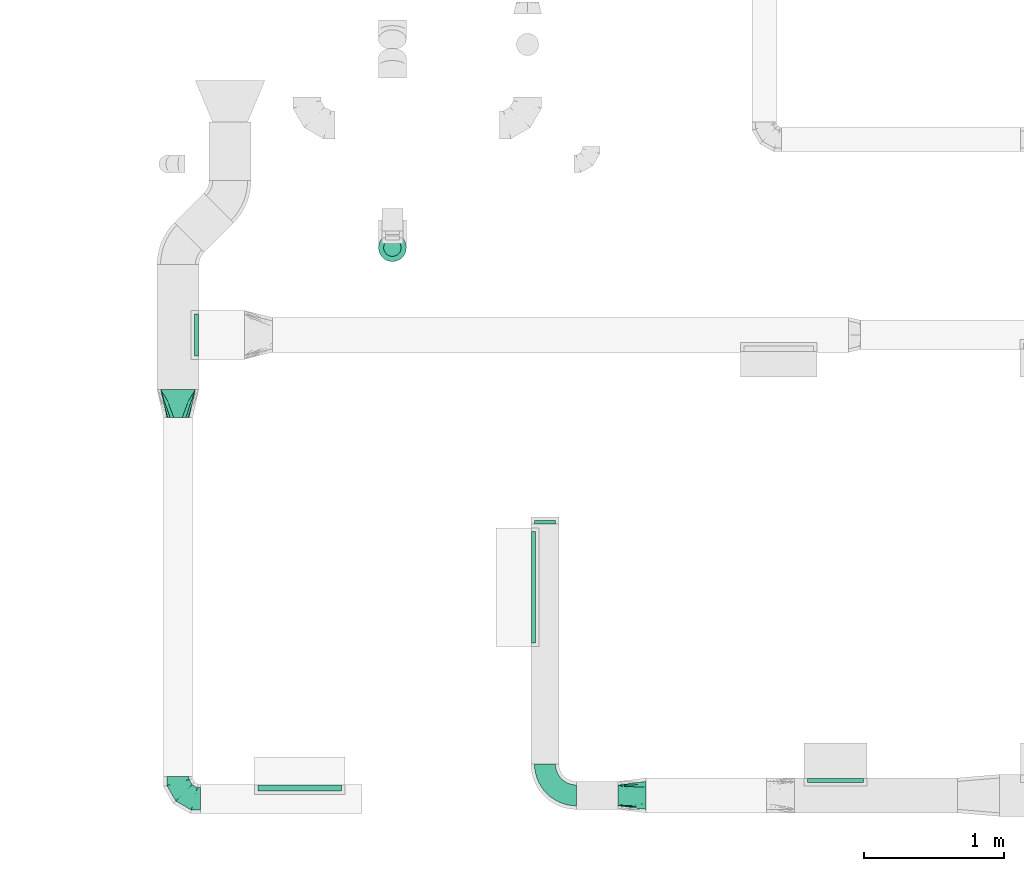
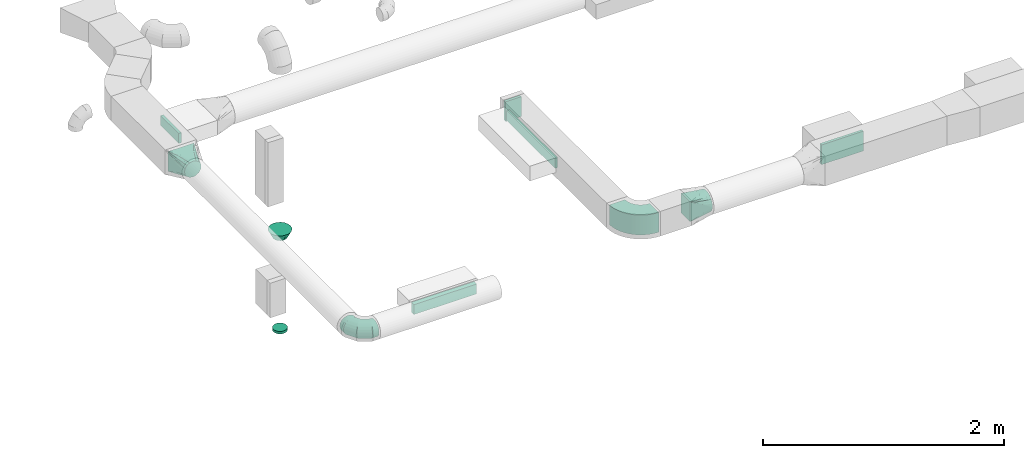
# One storey, part 49 of 97: 11 flow fittings.
"""IFC2X3 building model written with IfcOpenShell, lengths in millimetres."""

from ifc_helpers import new_model, entity, si_unit, converted_unit, derived_unit, direction, frame, frame_2d, origin, origin_2d_with_axis, place, context, subcontext, project, spatial, polyline, circle_curve, parameter, trimmed, segment, composite_curve, rectangle, circle, outline, extrude, faceted_brep, source, transform, mapped, material, type_object, type_shapes, element, save


model = new_model("IFC2X3")

# Units and contexts
model_context = context("Model", 3, precision=0.01, world=origin(), true_north=direction((6.12303176911189e-17, 1.0)))
body_context = subcontext(model_context, "Body", "Model", "MODEL_VIEW")
ifc_project = project(units=[si_unit("LENGTHUNIT", "METRE", prefix="MILLI"), si_unit("AREAUNIT", "SQUARE_METRE"), si_unit("VOLUMEUNIT", "CUBIC_METRE"), converted_unit("PLANEANGLEUNIT", "DEGREE", entity("IfcRatioMeasure", 0.0174532925199433), si_unit("PLANEANGLEUNIT", "RADIAN"), dimensions=[0, 0, 0, 0, 0, 0, 0]), si_unit("MASSUNIT", "GRAM", prefix="KILO"), derived_unit("MASSDENSITYUNIT", [(si_unit("MASSUNIT", "GRAM", prefix="KILO"), 1), (si_unit("LENGTHUNIT", "METRE"), -3)]), derived_unit("MOMENTOFINERTIAUNIT", [(si_unit("LENGTHUNIT", "METRE"), 4)]), si_unit("TIMEUNIT", "SECOND"), si_unit("FREQUENCYUNIT", "HERTZ"), si_unit("THERMODYNAMICTEMPERATUREUNIT", "DEGREE_CELSIUS"), derived_unit("THERMALTRANSMITTANCEUNIT", [(si_unit("MASSUNIT", "GRAM", prefix="KILO"), 1), (si_unit("THERMODYNAMICTEMPERATUREUNIT", "KELVIN"), -1), (si_unit("TIMEUNIT", "SECOND"), -3)]), derived_unit("VOLUMETRICFLOWRATEUNIT", [(si_unit("LENGTHUNIT", "METRE"), 3), (si_unit("TIMEUNIT", "SECOND"), -1)]), derived_unit("MASSFLOWRATEUNIT", [(si_unit("MASSUNIT", "GRAM", prefix="KILO"), 1), (si_unit("TIMEUNIT", "SECOND"), -1)]), derived_unit("ROTATIONALFREQUENCYUNIT", [(si_unit("TIMEUNIT", "SECOND"), -1)]), si_unit("ELECTRICCURRENTUNIT", "AMPERE"), si_unit("ELECTRICVOLTAGEUNIT", "VOLT"), si_unit("POWERUNIT", "WATT"), si_unit("FORCEUNIT", "NEWTON", prefix="KILO"), si_unit("ILLUMINANCEUNIT", "LUX"), si_unit("LUMINOUSFLUXUNIT", "LUMEN"), si_unit("LUMINOUSINTENSITYUNIT", "CANDELA"), derived_unit("USERDEFINED", [(si_unit("MASSUNIT", "GRAM", prefix="KILO"), -1), (si_unit("LENGTHUNIT", "METRE"), -2), (si_unit("TIMEUNIT", "SECOND"), 3), (si_unit("LUMINOUSFLUXUNIT", "LUMEN"), 1)]), derived_unit("LINEARVELOCITYUNIT", [(si_unit("LENGTHUNIT", "METRE"), 1), (si_unit("TIMEUNIT", "SECOND"), -1)]), si_unit("PRESSUREUNIT", "PASCAL"), derived_unit("USERDEFINED", [(si_unit("LENGTHUNIT", "METRE"), -2), (si_unit("MASSUNIT", "GRAM", prefix="KILO"), 1), (si_unit("TIMEUNIT", "SECOND"), -2)]), derived_unit("LINEARFORCEUNIT", [(si_unit("MASSUNIT", "GRAM", prefix="KILO"), 1), (si_unit("LENGTHUNIT", "METRE"), 1), (si_unit("TIMEUNIT", "SECOND"), -2), (si_unit("LENGTHUNIT", "METRE"), -1)]), derived_unit("PLANARFORCEUNIT", [(si_unit("MASSUNIT", "GRAM", prefix="KILO"), 1), (si_unit("LENGTHUNIT", "METRE"), 1), (si_unit("TIMEUNIT", "SECOND"), -2), (si_unit("LENGTHUNIT", "METRE"), -2)])], contexts=[model_context])

# Site, building, storey
site_placement = place(None, origin())
site = spatial("IfcSite", under=ifc_project, at=site_placement, CompositionType="ELEMENT")
building_placement = place(site_placement, origin())
building = spatial("IfcBuilding", under=site, at=building_placement, CompositionType="ELEMENT")
storey_placement = place(building_placement, frame((0.0, 0.0, -4900.0)))
storey = spatial("IfcBuildingStorey", under=building, at=storey_placement, CompositionType="ELEMENT", Elevation=-4900.0)

# Flow fittings
ifc_material = material()
duct_fitting_type_1 = type_object("IfcDuctFittingType", PredefinedType="NOTDEFINED", material=ifc_material)
shared_shape_1 = source(origin(), body_context, "Body", "SweptSolid", [
    extrude(rectangle(XDim=26.0960000000006, YDim=400.0, at=origin_2d_with_axis()), frame((6.95, 0.0, -100.0)), (0.0, 0.0, 1.0), 200.0),
])
type_shapes(duct_fitting_type_1, [shared_shape_1])
flow_fitting_1_placement = place(storey_placement, frame((46800.54, 373.87, 4200.0), z_axis=(0.0, 0.0, -1.0), x_axis=(0.0, 1.0, 0.0)))
element("IfcFlowFitting", 1, at=flow_fitting_1_placement, inside=storey, type_object=duct_fitting_type_1, material=ifc_material, context=body_context, shape_type="MappedRepresentation", body=[
    mapped(shared_shape_1, transform((0.0, 0.0, 0.0), scale=1.0)),
])
duct_fitting_type_2 = type_object("IfcDuctFittingType", PredefinedType="NOTDEFINED", material=ifc_material)
shared_shape_2 = source(origin(), body_context, "Body", "SweptSolid", [
    extrude(rectangle(XDim=600.0, YDim=43.6460200160145, at=origin_2d_with_axis()), frame((-1.82, 0.0, -50.0), z_axis=(0.0, 0.0, 1.0), x_axis=(0.0, -1.0, 0.0)), (0.0, 0.0, 1.0), 100.0),
])
type_shapes(duct_fitting_type_2, [shared_shape_2])
flow_fitting_2_placement = place(storey_placement, frame((42962.03, 328.86, 4050.0), z_axis=(0.0, 0.0, -1.0), x_axis=(0.0, 1.0, 0.0)))
element("IfcFlowFitting", 2, at=flow_fitting_2_placement, inside=storey, type_object=duct_fitting_type_2, material=ifc_material, context=body_context, shape_type="MappedRepresentation", body=[
    mapped(shared_shape_2, transform((0.0, 0.0, 0.0), scale=1.0)),
])
duct_fitting_type_3 = type_object("IfcDuctFittingType", PredefinedType="NOTDEFINED", material=ifc_material)
shared_shape_3 = source(origin(), body_context, "Body", "SweptSolid", [
    extrude(rectangle(XDim=300.0, YDim=26.0960000000173, at=origin_2d_with_axis()), frame((6.95, 0.0, -50.0), z_axis=(0.0, 0.0, 1.0), x_axis=(0.0, -1.0, 0.0)), (0.0, 0.0, 1.0), 100.0),
])
type_shapes(duct_fitting_type_3, [shared_shape_3])
flow_fitting_3_placement = place(storey_placement, frame((42214.6, 3573.53, 4050.0), z_axis=(0.0, 0.0, -1.0), x_axis=(1.0, 0.0, 0.0)))
element("IfcFlowFitting", 3, at=flow_fitting_3_placement, inside=storey, type_object=duct_fitting_type_3, material=ifc_material, context=body_context, shape_type="MappedRepresentation", body=[
    mapped(shared_shape_3, transform((0.0, 0.0, 0.0), scale=1.0)),
])
duct_fitting_type_4 = type_object("IfcDuctFittingType", PredefinedType="NOTDEFINED", material=ifc_material)
shared_shape_4 = source(origin(), body_context, "Body", "SweptSolid", [
    extrude(rectangle(XDim=24.9999999999999, YDim=150.0, at=origin_2d_with_axis()), frame((12.5, 0.0, -100.0)), (0.0, 0.0, 1.0), 200.0),
])
type_shapes(duct_fitting_type_4, [shared_shape_4])
flow_fitting_4_placement = place(storey_placement, frame((44718.59, 2217.15, 4200.0), z_axis=(0.0, 0.0, 1.0), x_axis=(0.0, 1.0, 0.0)))
element("IfcFlowFitting", 4, at=flow_fitting_4_placement, inside=storey, type_object=duct_fitting_type_4, material=ifc_material, context=body_context, shape_type="MappedRepresentation", body=[
    mapped(shared_shape_4, transform((0.0, 0.0, 0.0), scale=1.0)),
])
duct_fitting_type_5 = type_object("IfcDuctFittingType", PredefinedType="NOTDEFINED", material=ifc_material)
shared_shape_5 = source(origin(), body_context, "Body", "SweptSolid", [
    extrude(rectangle(XDim=26.0960000000012, YDim=800.0, at=origin_2d_with_axis()), frame((6.95, 0.0, -50.0)), (0.0, 0.0, 1.0), 100.0),
])
type_shapes(duct_fitting_type_5, [shared_shape_5])
flow_fitting_5_placement = place(storey_placement, frame((44643.59, 1766.12, 4200.0), z_axis=(0.0, 0.0, -1.0), x_axis=(-1.0, 0.0, 0.0)))
element("IfcFlowFitting", 5, at=flow_fitting_5_placement, inside=storey, type_object=duct_fitting_type_5, material=ifc_material, context=body_context, shape_type="MappedRepresentation", body=[
    mapped(shared_shape_5, transform((0.0, 0.0, 0.0), scale=1.0)),
])
duct_fitting_type_6 = type_object("IfcDuctFittingType", PredefinedType="NOTDEFINED", material=ifc_material)
shared_shape_6 = source(origin(), body_context, "Body", "SweptSolid", [
    extrude(circle(Radius=62.4999999999996, at=origin_2d_with_axis()), frame((0.0, 0.0, 0.0), z_axis=(1.0, 0.0, 0.0), x_axis=(0.0, 1.0, 0.0)), (0.0, 0.0, 1.0), 25.0000000000018),
])
type_shapes(duct_fitting_type_6, [shared_shape_6])
flow_fitting_6_placement = place(storey_placement, frame((43625.66, 4198.32, 1174.5), z_axis=(-1.0, 0.0, 0.0), x_axis=(0.0, 0.0, -1.0)))
element("IfcFlowFitting", 6, at=flow_fitting_6_placement, inside=storey, type_object=duct_fitting_type_6, material=ifc_material, context=body_context, shape_type="MappedRepresentation", body=[
    mapped(shared_shape_6, transform((0.0, 0.0, 0.0), scale=1.0)),
])
duct_fitting_type_7 = type_object("IfcDuctFittingType", PredefinedType="NOTDEFINED", material=ifc_material)
shared_shape_7 = source(origin(), body_context, "Body", "Brep", [
    faceted_brep([(-160.0, 0.0, -80.0), (-160.0, -20.71, -77.27), (-160.0, -40.0, -69.28), (-160.0, -56.57, -56.57), (-160.0, -69.28, -40.0), (-160.0, -77.27, -20.71), (-160.0, -80.0, 0.0), (-160.0, -77.27, 20.71), (-160.0, -69.28, 40.0), (-160.0, -56.57, 56.57), (-160.0, -40.0, 69.28), (-160.0, -20.71, 77.27), (-160.0, 0.0, 80.0), (-160.0, 20.71, 77.27), (-160.0, 40.0, 69.28), (-160.0, 56.57, 56.57), (-160.0, 69.28, 40.0), (-160.0, 77.27, 20.71), (-160.0, 80.0, 0.0), (-160.0, 77.27, -20.71), (-160.0, 69.28, -40.0), (-160.0, 56.57, -56.57), (-160.0, 40.0, -69.28), (-160.0, 20.71, -77.27), (-122.68, 20.71, 77.27), (-127.85, 40.0, 69.28), (-117.13, 0.0, 80.0), (-132.29, 56.57, 56.57), (-137.83, 77.27, 20.71), (-138.56, 80.0, 0.0), (-135.69, 69.28, 40.0), (-135.69, 69.28, -40.0), (-132.29, 56.57, -56.57), (-137.83, 77.27, -20.71), (-122.68, 20.71, -77.27), (-117.13, 0.0, -80.0), (-127.85, 40.0, -69.28), (-111.58, -20.71, -77.27), (-106.41, -40.0, -69.28), (-101.97, -56.57, -56.57), (-98.56, -69.28, -40.0), (-96.42, -77.27, -20.71), (-95.69, -80.0, 0.0), (-96.42, -77.27, 20.71), (-98.56, -69.28, 40.0), (-101.97, -56.57, 56.57), (-106.41, -40.0, 69.28), (-111.58, -20.71, 77.27), (-58.03, 58.03, 77.27), (-72.15, 72.15, 69.28), (-42.87, 42.87, 80.0), (-84.28, 84.28, 56.57), (-93.59, 93.59, 40.0), (-99.44, 99.44, 20.71), (-101.44, 101.44, 0.0), (-99.44, 99.44, -20.71), (-93.59, 93.59, -40.0), (-84.28, 84.28, -56.57), (-58.03, 58.03, -77.27), (-42.87, 42.87, -80.0), (-72.15, 72.15, -69.28), (-27.71, 27.71, -77.27), (-13.59, 13.59, -69.28), (-1.46, 1.46, -56.57), (7.85, -7.85, -40.0), (13.7, -13.7, -20.71), (15.69, -15.69, 0.0), (13.7, -13.7, 20.71), (7.85, -7.85, 40.0), (-1.46, 1.46, 56.57), (-13.59, 13.59, 69.28), (-27.71, 27.71, 77.27), (-20.71, 122.68, 77.27), (-40.0, 127.85, 69.28), (0.0, 117.13, 80.0), (-56.57, 132.29, 56.57), (-69.28, 135.69, 40.0), (-77.27, 137.83, 20.71), (-80.0, 138.56, 0.0), (-77.27, 137.83, -20.71), (-69.28, 135.69, -40.0), (-56.57, 132.29, -56.57), (-20.71, 122.68, -77.27), (0.0, 117.13, -80.0), (-40.0, 127.85, -69.28), (20.71, 111.58, -77.27), (40.0, 106.41, -69.28), (56.57, 101.97, -56.57), (69.28, 98.56, -40.0), (77.27, 96.42, -20.71), (80.0, 95.69, 0.0), (77.27, 96.42, 20.71), (69.28, 98.56, 40.0), (56.57, 101.97, 56.57), (40.0, 106.41, 69.28), (20.71, 111.58, 77.27), (-20.71, 160.0, -77.27), (-40.0, 160.0, -69.28), (-56.57, 160.0, -56.57), (-69.28, 160.0, -40.0), (-77.27, 160.0, -20.71), (-80.0, 160.0, 0.0), (-77.27, 160.0, 20.71), (-69.28, 160.0, 40.0), (-56.57, 160.0, 56.57), (-40.0, 160.0, 69.28), (-20.71, 160.0, 77.27), (0.0, 160.0, 80.0), (20.71, 160.0, 77.27), (40.0, 160.0, 69.28), (56.57, 160.0, 56.57), (69.28, 160.0, 40.0), (77.27, 160.0, 20.71), (80.0, 160.0, 0.0), (77.27, 160.0, -20.71), (69.28, 160.0, -40.0), (56.57, 160.0, -56.57), (40.0, 160.0, -69.28), (20.71, 160.0, -77.27), (0.0, 160.0, -80.0)], [[[0, 1, 2, 3, 4, 5, 6, 7, 8, 9, 10, 11, 12, 13, 14, 15, 16, 17, 18, 19, 20, 21, 22, 23]], [[24, 25, 14, 13]], [[26, 24, 13, 12]], [[14, 25, 27, 15]], [[28, 29, 18, 17]], [[30, 28, 17, 16]], [[15, 27, 30, 16]], [[20, 31, 32, 21]], [[33, 31, 20, 19]], [[18, 29, 33, 19]], [[34, 35, 0, 23]], [[36, 34, 23, 22]], [[32, 36, 22, 21]], [[1, 0, 35, 37]], [[2, 1, 37, 38]], [[3, 2, 38, 39]], [[5, 4, 40, 41]], [[6, 5, 41, 42]], [[39, 40, 4, 3]], [[6, 42, 43, 7]], [[7, 43, 44, 8]], [[8, 44, 45, 9]], [[9, 45, 46, 10]], [[10, 46, 47, 11]], [[26, 12, 11, 47]], [[48, 49, 25, 24]], [[50, 48, 24, 26]], [[27, 25, 49, 51]], [[52, 53, 28, 30]], [[51, 52, 30, 27]], [[29, 28, 53, 54]], [[55, 56, 31, 33]], [[54, 55, 33, 29]], [[32, 31, 56, 57]], [[58, 59, 35, 34]], [[60, 58, 34, 36]], [[57, 60, 36, 32]], [[37, 35, 59, 61]], [[38, 37, 61, 62]], [[39, 38, 62, 63]], [[41, 40, 64, 65]], [[42, 41, 65, 66]], [[63, 64, 40, 39]], [[43, 42, 66, 67]], [[44, 43, 67, 68]], [[68, 69, 45, 44]], [[46, 45, 69, 70]], [[47, 46, 70, 71]], [[26, 47, 71, 50]], [[72, 73, 49, 48]], [[74, 72, 48, 50]], [[51, 49, 73, 75]], [[76, 77, 53, 52]], [[75, 76, 52, 51]], [[54, 53, 77, 78]], [[79, 80, 56, 55]], [[78, 79, 55, 54]], [[57, 56, 80, 81]], [[82, 83, 59, 58]], [[84, 82, 58, 60]], [[81, 84, 60, 57]], [[61, 59, 83, 85]], [[62, 61, 85, 86]], [[63, 62, 86, 87]], [[65, 64, 88, 89]], [[66, 65, 89, 90]], [[87, 88, 64, 63]], [[67, 66, 90, 91]], [[68, 67, 91, 92]], [[92, 93, 69, 68]], [[70, 69, 93, 94]], [[71, 70, 94, 95]], [[50, 71, 95, 74]], [[96, 97, 98, 99, 100, 101, 102, 103, 104, 105, 106, 107, 108, 109, 110, 111, 112, 113, 114, 115, 116, 117, 118, 119]], [[72, 74, 107, 106]], [[73, 72, 106, 105]], [[75, 73, 105, 104]], [[77, 76, 103, 102]], [[78, 77, 102, 101]], [[75, 104, 103, 76]], [[78, 101, 100, 79]], [[79, 100, 99, 80]], [[80, 99, 98, 81]], [[84, 97, 96, 82]], [[82, 96, 119, 83]], [[84, 81, 98, 97]], [[118, 117, 86, 85]], [[119, 118, 85, 83]], [[116, 87, 86, 117]], [[88, 115, 114, 89]], [[89, 114, 113, 90]], [[115, 88, 87, 116]], [[112, 111, 92, 91]], [[113, 112, 91, 90]], [[111, 110, 93, 92]], [[95, 94, 109, 108]], [[74, 95, 108, 107]], [[110, 109, 94, 93]]]),
])
type_shapes(duct_fitting_type_7, [shared_shape_7])
flow_fitting_7_placement = place(storey_placement, frame((42089.6, 248.86, 4050.0), z_axis=(0.0, 0.0, 1.0), x_axis=(0.0, -1.0, 0.0)))
element("IfcFlowFitting", 7, at=flow_fitting_7_placement, inside=storey, type_object=duct_fitting_type_7, material=ifc_material, context=body_context, shape_type="MappedRepresentation", body=[
    mapped(shared_shape_7, transform((0.0, 0.0, 0.0), scale=1.0)),
])
duct_fitting_type_8 = type_object("IfcDuctFittingType", PredefinedType="NOTDEFINED", material=ifc_material)
shared_shape_8 = source(origin(), body_context, "Body", "Brep", [
    faceted_brep([(200.0, 30.61, 73.91), (200.0, 22.87, 75.45), (200.0, 15.12, 76.99), (200.0, 11.34, 77.74), (200.0, 7.56, 78.5), (200.0, 0.0, 80.0), (200.0, -7.56, 78.5), (200.0, -15.12, 76.99), (200.0, -18.99, 76.22), (200.0, -22.87, 75.45), (200.0, -30.61, 73.91), (200.0, -37.1, 69.57), (200.0, -43.59, 65.24), (200.0, -50.08, 60.9), (200.0, -56.57, 56.57), (200.0, -60.9, 50.08), (200.0, -65.24, 43.59), (200.0, -69.57, 37.1), (200.0, -73.91, 30.61), (200.0, -75.45, 22.87), (200.0, -76.99, 15.12), (200.0, -77.74, 11.34), (200.0, -78.5, 7.56), (200.0, -80.0, 0.0), (200.0, -78.5, -7.56), (200.0, -76.99, -15.12), (200.0, -76.22, -18.99), (200.0, -75.45, -22.87), (200.0, -73.91, -30.61), (200.0, -69.57, -37.1), (200.0, -65.24, -43.59), (200.0, -60.9, -50.08), (200.0, -56.57, -56.57), (200.0, -50.08, -60.9), (200.0, -43.59, -65.24), (200.0, -37.1, -69.57), (200.0, -30.61, -73.91), (200.0, -22.87, -75.45), (200.0, -15.12, -76.99), (200.0, -11.34, -77.74), (200.0, -7.56, -78.5), (200.0, 0.0, -80.0), (200.0, 7.56, -78.5), (200.0, 15.12, -76.99), (200.0, 18.99, -76.22), (200.0, 22.87, -75.45), (200.0, 30.61, -73.91), (200.0, 37.1, -69.57), (200.0, 43.59, -65.24), (200.0, 50.08, -60.9), (200.0, 56.57, -56.57), (200.0, 60.9, -50.08), (200.0, 65.24, -43.59), (200.0, 69.57, -37.1), (200.0, 73.91, -30.61), (200.0, 75.45, -22.87), (200.0, 76.99, -15.12), (200.0, 77.74, -11.34), (200.0, 78.5, -7.56), (200.0, 80.0, 0.0), (200.0, 78.5, 7.56), (200.0, 76.99, 15.12), (200.0, 76.22, 18.99), (200.0, 75.45, 22.87), (200.0, 73.91, 30.61), (200.0, 69.57, 37.1), (200.0, 65.24, 43.59), (200.0, 60.9, 50.08), (200.0, 56.57, 56.57), (200.0, 50.08, 60.9), (200.0, 43.59, 65.24), (200.0, 37.1, 69.57), (0.0, -125.0, 100.0), (0.0, 125.0, 100.0), (0.0, 125.0, -100.0), (0.0, -125.0, -100.0), (52.06, -92.46, 94.79), (78.09, -76.2, 92.19), (176.03, -14.98, 82.4), (152.06, -29.96, 84.79), (128.09, -44.95, 87.19), (104.11, -59.93, 89.59), (100.0, -92.44, 76.52), (78.09, -107.43, 60.96), (104.11, -101.57, 47.94), (128.09, -96.18, 35.96), (152.06, -90.79, 23.97), (164.04, -88.09, 17.98), (176.03, -85.39, 11.99), (26.03, -119.14, 86.99), (52.06, -113.29, 73.97), (26.03, -108.73, 97.4), (26.03, -119.14, -86.99), (52.06, -113.29, -73.97), (78.09, -107.43, -60.96), (104.11, -101.57, -47.94), (128.09, -96.18, -35.96), (152.06, -90.79, -23.97), (176.03, -85.39, -11.99), (100.0, -89.02, -79.94), (78.09, -76.2, -92.19), (104.11, -59.93, -89.59), (128.09, -44.95, -87.19), (152.06, -29.96, -84.79), (164.04, -22.47, -83.6), (176.03, -14.98, -82.4), (26.03, -108.73, -97.4), (52.06, -92.46, -94.79), (26.03, 108.73, -97.4), (52.06, 92.46, -94.79), (78.09, 76.2, -92.19), (104.11, 59.93, -89.59), (128.09, 44.95, -87.19), (152.06, 29.96, -84.79), (176.03, 14.98, -82.4), (100.0, 92.44, -76.52), (78.09, 107.43, -60.96), (104.11, 101.57, -47.94), (128.09, 96.18, -35.96), (152.06, 90.79, -23.97), (164.04, 88.09, -17.98), (176.03, 85.39, -11.99), (26.03, 119.14, -86.99), (52.06, 113.29, -73.97), (26.03, 119.14, 86.99), (52.06, 113.29, 73.97), (78.09, 107.43, 60.96), (104.11, 101.57, 47.94), (128.09, 96.18, 35.96), (152.06, 90.79, 23.97), (176.03, 85.39, 11.99), (100.0, 89.02, 79.94), (78.09, 76.2, 92.19), (104.11, 59.93, 89.59), (128.09, 44.95, 87.19), (152.06, 29.96, 84.79), (164.04, 22.47, 83.6), (176.03, 14.98, 82.4), (26.03, 108.73, 97.4), (52.06, 92.46, 94.79)], [[[0, 1, 2, 3, 4, 5, 6, 7, 8, 9, 10, 11, 12, 13, 14, 15, 16, 17, 18, 19, 20, 21, 22, 23, 24, 25, 26, 27, 28, 29, 30, 31, 32, 33, 34, 35, 36, 37, 38, 39, 40, 41, 42, 43, 44, 45, 46, 47, 48, 49, 50, 51, 52, 53, 54, 55, 56, 57, 58, 59, 60, 61, 62, 63, 64, 65, 66, 67, 68, 69, 70, 71]], [[72, 73, 74, 75]], [[76, 12, 77]], [[12, 11, 10, 77]], [[78, 79, 80, 81, 77, 10, 9, 8, 7, 6, 5]], [[13, 82, 14]], [[20, 19, 18, 83, 84, 85, 86, 87, 88, 23, 22, 21]], [[82, 72, 89]], [[82, 15, 14]], [[83, 16, 90]], [[91, 72, 82]], [[18, 17, 16, 83]], [[90, 16, 15]], [[15, 82, 89]], [[90, 15, 89]], [[76, 13, 12]], [[13, 76, 91]], [[82, 13, 91]], [[88, 87, 86, 85, 84, 83, 90, 89, 72, 75, 92, 93, 94, 95, 96, 97, 98, 23]], [[93, 30, 94]], [[30, 29, 28, 94]], [[98, 97, 96, 95, 94, 28, 27, 26, 25, 24, 23]], [[31, 99, 32]], [[38, 37, 36, 100, 101, 102, 103, 104, 105, 41, 40, 39]], [[99, 75, 106]], [[99, 33, 32]], [[100, 34, 107]], [[92, 75, 99]], [[36, 35, 34, 100]], [[107, 34, 33]], [[33, 99, 106]], [[107, 33, 106]], [[93, 31, 30]], [[31, 93, 92]], [[99, 31, 92]], [[105, 104, 103, 102, 101, 100, 107, 106, 75, 74, 108, 109, 110, 111, 112, 113, 114, 41]], [[109, 48, 110]], [[48, 47, 46, 110]], [[114, 113, 112, 111, 110, 46, 45, 44, 43, 42, 41]], [[49, 115, 50]], [[56, 55, 54, 116, 117, 118, 119, 120, 121, 59, 58, 57]], [[115, 74, 122]], [[115, 51, 50]], [[116, 52, 123]], [[108, 74, 115]], [[54, 53, 52, 116]], [[123, 52, 51]], [[51, 115, 122]], [[123, 51, 122]], [[109, 49, 48]], [[49, 109, 108]], [[115, 49, 108]], [[74, 73, 124, 125, 126, 127, 128, 129, 130, 59, 121, 120, 119, 118, 117, 116, 123, 122]], [[125, 66, 126]], [[66, 65, 64, 126]], [[130, 129, 128, 127, 126, 64, 63, 62, 61, 60, 59]], [[67, 131, 68]], [[2, 1, 0, 132, 133, 134, 135, 136, 137, 5, 4, 3]], [[131, 73, 138]], [[131, 69, 68]], [[132, 70, 139]], [[124, 73, 131]], [[0, 71, 70, 132]], [[139, 70, 69]], [[69, 131, 138]], [[139, 69, 138]], [[125, 67, 66]], [[67, 125, 124]], [[131, 67, 124]], [[73, 72, 91, 76, 77, 81, 80, 79, 78, 5, 137, 136, 135, 134, 133, 132, 139, 138]]]),
])
type_shapes(duct_fitting_type_8, [shared_shape_8])
flow_fitting_8_placement = place(storey_placement, frame((42089.6, 3181.98, 4050.0), z_axis=(0.0, 0.0, 1.0), x_axis=(0.0, -1.0, 0.0)))
element("IfcFlowFitting", 8, at=flow_fitting_8_placement, inside=storey, type_object=duct_fitting_type_8, material=ifc_material, context=body_context, shape_type="MappedRepresentation", body=[
    mapped(shared_shape_8, transform((0.0, 0.0, 0.0), scale=1.0)),
])
duct_fitting_type_9 = type_object("IfcDuctFittingType", PredefinedType="NOTDEFINED", material=ifc_material)
shared_shape_9 = source(origin(), body_context, "Body", "Brep", [
    faceted_brep([(200.0, 30.9, 95.11), (200.0, 19.08, 96.98), (200.0, 9.54, 98.49), (200.0, 4.77, 99.24), (200.0, 0.0, 100.0), (200.0, -4.77, 99.24), (200.0, -9.54, 98.49), (200.0, -19.08, 96.98), (200.0, -30.9, 95.11), (200.0, -44.84, 88.0), (200.0, -58.78, 80.9), (200.0, -69.84, 69.84), (200.0, -80.9, 58.78), (200.0, -88.0, 44.84), (200.0, -95.11, 30.9), (200.0, -96.98, 19.08), (200.0, -98.49, 9.54), (200.0, -99.24, 4.77), (200.0, -100.0, 0.0), (200.0, -99.24, -4.77), (200.0, -98.49, -9.54), (200.0, -96.98, -19.08), (200.0, -95.11, -30.9), (200.0, -88.0, -44.84), (200.0, -80.9, -58.78), (200.0, -69.84, -69.84), (200.0, -58.78, -80.9), (200.0, -44.84, -88.0), (200.0, -30.9, -95.11), (200.0, -19.08, -96.98), (200.0, -9.54, -98.49), (200.0, -4.77, -99.24), (200.0, 0.0, -100.0), (200.0, 4.77, -99.24), (200.0, 9.54, -98.49), (200.0, 19.08, -96.98), (200.0, 30.9, -95.11), (200.0, 44.84, -88.0), (200.0, 58.78, -80.9), (200.0, 69.84, -69.84), (200.0, 80.9, -58.78), (200.0, 88.0, -44.84), (200.0, 95.11, -30.9), (200.0, 96.98, -19.08), (200.0, 98.49, -9.54), (200.0, 99.24, -4.77), (200.0, 100.0, 0.0), (200.0, 99.24, 4.77), (200.0, 98.49, 9.54), (200.0, 96.98, 19.08), (200.0, 95.11, 30.9), (200.0, 88.0, 44.84), (200.0, 80.9, 58.78), (200.0, 69.84, 69.84), (200.0, 58.78, 80.9), (200.0, 44.84, 88.0), (0.0, -75.0, 100.0), (0.0, 75.0, 100.0), (0.0, 75.0, -100.0), (0.0, -75.0, -100.0), (104.11, -35.96, 100.0), (100.0, -70.65, 87.43), (26.03, -65.24, 100.0), (78.09, -45.72, 100.0), (52.06, -55.48, 100.0), (188.01, -4.49, 100.0), (176.03, -8.99, 100.0), (152.06, -17.98, 100.0), (128.09, -26.97, 100.0), (52.06, -81.51, 73.97), (78.09, -84.76, 60.96), (104.11, -88.01, 47.94), (128.09, -91.01, 35.96), (152.06, -94.01, 23.97), (176.03, -97.0, 11.99), (188.01, -98.5, 5.99), (26.03, -78.25, 86.99), (26.03, -78.25, -86.99), (52.06, -81.51, -73.97), (78.09, -84.76, -60.96), (104.11, -88.01, -47.94), (128.09, -91.01, -35.96), (152.06, -94.01, -23.97), (176.03, -97.0, -11.99), (188.01, -98.5, -5.99), (100.0, -74.93, -83.15), (52.06, -55.48, -100.0), (78.09, -45.72, -100.0), (104.11, -35.96, -100.0), (128.09, -26.97, -100.0), (152.06, -17.98, -100.0), (176.03, -8.99, -100.0), (188.01, -4.49, -100.0), (26.03, -65.24, -100.0), (26.03, 65.24, -100.0), (52.06, 55.48, -100.0), (78.09, 45.72, -100.0), (104.11, 35.96, -100.0), (128.09, 26.97, -100.0), (152.06, 17.98, -100.0), (176.03, 8.99, -100.0), (188.01, 4.49, -100.0), (100.0, 70.65, -87.43), (52.06, 81.51, -73.97), (78.09, 84.76, -60.96), (104.11, 88.01, -47.94), (128.09, 91.01, -35.96), (152.06, 94.01, -23.97), (176.03, 97.0, -11.99), (188.01, 98.5, -5.99), (26.03, 78.25, -86.99), (26.03, 78.25, 86.99), (52.06, 81.51, 73.97), (78.09, 84.76, 60.96), (104.11, 88.01, 47.94), (128.09, 91.01, 35.96), (152.06, 94.01, 23.97), (176.03, 97.0, 11.99), (188.01, 98.5, 5.99), (100.0, 74.93, 83.15), (52.06, 55.48, 100.0), (78.09, 45.72, 100.0), (104.11, 35.96, 100.0), (128.09, 26.97, 100.0), (152.06, 17.98, 100.0), (176.03, 8.99, 100.0), (188.01, 4.49, 100.0), (26.03, 65.24, 100.0)], [[[0, 1, 2, 3, 4, 5, 6, 7, 8, 9, 10, 11, 12, 13, 14, 15, 16, 17, 18, 19, 20, 21, 22, 23, 24, 25, 26, 27, 28, 29, 30, 31, 32, 33, 34, 35, 36, 37, 38, 39, 40, 41, 42, 43, 44, 45, 46, 47, 48, 49, 50, 51, 52, 53, 54, 55]], [[56, 57, 58, 59]], [[60, 9, 8]], [[56, 61, 62]], [[9, 60, 63, 64]], [[65, 66, 67, 68, 60, 8, 7, 6, 5, 4]], [[62, 61, 10]], [[13, 69, 70, 71]], [[64, 10, 9]], [[14, 71, 72, 73, 74, 75, 18, 17, 16, 15]], [[12, 76, 69]], [[71, 14, 13]], [[61, 76, 11]], [[10, 64, 62]], [[76, 12, 11]], [[10, 61, 11]], [[61, 56, 76]], [[69, 13, 12]], [[75, 74, 73, 72, 71, 70, 69, 76, 56, 59, 77, 78, 79, 80, 81, 82, 83, 84, 18]], [[80, 23, 22]], [[59, 85, 77]], [[23, 80, 79, 78]], [[84, 83, 82, 81, 80, 22, 21, 20, 19, 18]], [[77, 85, 24]], [[27, 86, 87, 88]], [[78, 24, 23]], [[28, 88, 89, 90, 91, 92, 32, 31, 30, 29]], [[26, 93, 86]], [[88, 28, 27]], [[85, 93, 25]], [[24, 78, 77]], [[93, 26, 25]], [[24, 85, 25]], [[85, 59, 93]], [[86, 27, 26]], [[92, 91, 90, 89, 88, 87, 86, 93, 59, 58, 94, 95, 96, 97, 98, 99, 100, 101, 32]], [[97, 37, 36]], [[58, 102, 94]], [[37, 97, 96, 95]], [[101, 100, 99, 98, 97, 36, 35, 34, 33, 32]], [[94, 102, 38]], [[41, 103, 104, 105]], [[95, 38, 37]], [[42, 105, 106, 107, 108, 109, 46, 45, 44, 43]], [[40, 110, 103]], [[105, 42, 41]], [[102, 110, 39]], [[38, 95, 94]], [[110, 40, 39]], [[38, 102, 39]], [[102, 58, 110]], [[103, 41, 40]], [[58, 57, 111, 112, 113, 114, 115, 116, 117, 118, 46, 109, 108, 107, 106, 105, 104, 103, 110]], [[114, 51, 50]], [[57, 119, 111]], [[51, 114, 113, 112]], [[118, 117, 116, 115, 114, 50, 49, 48, 47, 46]], [[111, 119, 52]], [[55, 120, 121, 122]], [[112, 52, 51]], [[0, 122, 123, 124, 125, 126, 4, 3, 2, 1]], [[54, 127, 120]], [[122, 0, 55]], [[119, 127, 53]], [[52, 112, 111]], [[127, 54, 53]], [[52, 119, 53]], [[119, 57, 127]], [[120, 55, 54]], [[57, 56, 62, 64, 63, 60, 68, 67, 66, 65, 4, 126, 125, 124, 123, 122, 121, 120, 127]]]),
])
type_shapes(duct_fitting_type_9, [shared_shape_9])
flow_fitting_9_placement = place(storey_placement, frame((45243.8, 273.87, 4200.0)))
element("IfcFlowFitting", 9, at=flow_fitting_9_placement, inside=storey, type_object=duct_fitting_type_9, material=ifc_material, context=body_context, shape_type="MappedRepresentation", body=[
    mapped(shared_shape_9, transform((0.0, 0.0, 0.0), scale=1.0)),
])
duct_fitting_type_10 = type_object("IfcDuctFittingType", PredefinedType="NOTDEFINED", material=ifc_material)
shared_shape_10 = source(origin(), body_context, "Body", "Brep", [
    faceted_brep([(75.0, -57.74, 23.92), (75.0, -60.12, 11.96), (75.0, -62.5, 0.0), (75.0, -60.12, -11.96), (75.0, -57.74, -23.92), (75.0, -50.97, -34.06), (75.0, -44.19, -44.19), (75.0, -34.06, -50.97), (75.0, -23.92, -57.74), (75.0, -11.96, -60.12), (75.0, 0.0, -62.5), (75.0, 11.96, -60.12), (75.0, 23.92, -57.74), (75.0, 34.06, -50.97), (75.0, 44.19, -44.19), (75.0, 50.97, -34.06), (75.0, 57.74, -23.92), (75.0, 60.12, -11.96), (75.0, 62.5, 0.0), (75.0, 60.12, 11.96), (75.0, 57.74, 23.92), (75.0, 50.97, 34.06), (75.0, 44.19, 44.19), (75.0, 34.06, 50.97), (75.0, 23.92, 57.74), (75.0, 11.96, 60.12), (75.0, 0.0, 62.5), (75.0, -11.96, 60.12), (75.0, -23.92, 57.74), (75.0, -34.06, 50.97), (75.0, -44.19, 44.19), (75.0, -50.97, 34.06), (0.0, -100.0, 0.0), (0.0, -95.11, 30.9), (0.0, -80.9, 58.78), (0.0, -58.78, 80.9), (0.0, -30.9, 95.11), (0.0, 0.0, 100.0), (0.0, 30.9, 95.11), (0.0, 58.78, 80.9), (0.0, 80.9, 58.78), (0.0, 95.11, 30.9), (0.0, 100.0, 0.0), (0.0, 95.11, -30.9), (0.0, 80.9, -58.78), (0.0, 58.78, -80.9), (0.0, 30.9, -95.11), (0.0, 0.0, -100.0), (0.0, -30.9, -95.11), (0.0, -58.78, -80.9), (0.0, -80.9, -58.78), (0.0, -95.11, -30.9)], [[[0, 1, 2, 3, 4, 5, 6, 7, 8, 9, 10, 11, 12, 13, 14, 15, 16, 17, 18, 19, 20, 21, 22, 23, 24, 25, 26, 27, 28, 29, 30, 31]], [[32, 33, 34, 35, 36, 37, 38, 39, 40, 41, 42, 43, 44, 45, 46, 47, 48, 49, 50, 51]], [[37, 25, 38]], [[41, 20, 19]], [[24, 39, 38]], [[40, 22, 21, 20]], [[23, 22, 39, 24]], [[18, 42, 19]], [[25, 24, 38]], [[40, 20, 41]], [[19, 42, 41]], [[25, 37, 26]], [[22, 40, 39]], [[32, 1, 33]], [[36, 28, 27]], [[0, 34, 33]], [[35, 30, 29, 28]], [[31, 30, 34, 0]], [[26, 37, 27]], [[1, 0, 33]], [[35, 28, 36]], [[27, 37, 36]], [[1, 32, 2]], [[30, 35, 34]], [[47, 9, 48]], [[51, 4, 3]], [[8, 49, 48]], [[50, 6, 5, 4]], [[7, 6, 49, 8]], [[2, 32, 3]], [[9, 8, 48]], [[50, 4, 51]], [[3, 32, 51]], [[9, 47, 10]], [[6, 50, 49]], [[42, 17, 43]], [[46, 12, 11]], [[16, 44, 43]], [[45, 14, 13, 12]], [[15, 14, 44, 16]], [[10, 47, 11]], [[17, 16, 43]], [[45, 12, 46]], [[11, 47, 46]], [[17, 42, 18]], [[14, 45, 44]]]),
])
type_shapes(duct_fitting_type_10, [shared_shape_10])
flow_fitting_10_placement = place(storey_placement, frame((43625.66, 4198.32, 2167.5), z_axis=(0.0, 1.0, 0.0), x_axis=(0.0, 0.0, -1.0)))
element("IfcFlowFitting", 10, at=flow_fitting_10_placement, inside=storey, type_object=duct_fitting_type_10, material=ifc_material, context=body_context, shape_type="MappedRepresentation", body=[
    mapped(shared_shape_10, transform((0.0, 0.0, 0.0), scale=1.0)),
])
duct_fitting_type_11 = type_object("IfcDuctFittingType", PredefinedType="NOTDEFINED", material=ifc_material)
shared_shape_11 = source(origin(), body_context, "Body", "SweptSolid", [
    extrude(outline(composite_curve([segment(polyline([(-187.5, -112.5), (-37.5, -112.5)]), True, "CONTINUOUS"), segment(trimmed(circle_curve(frame_2d((112.5, -112.5), x_axis=(0.0, 1.0)), 150.0), [parameter(0.0)], [parameter(90.0000000000001)], True, "PARAMETER"), False, "CONTINUOUS"), segment(polyline([(112.5, 37.5), (112.5, 187.5)]), True, "CONTINUOUS"), segment(trimmed(circle_curve(frame_2d((112.5, -112.5), x_axis=(0.0, 1.0)), 300.0), [parameter(0.0)], [parameter(90.0000000000001)], True, "PARAMETER"), True, "CONTINUOUS")], self_intersect=False)), frame((-112.5, 112.5, -100.0), z_axis=(0.0, 0.0, 1.0), x_axis=(-1.0, 0.0, 0.0)), (0.0, 0.0, 1.0), 200.0),
])
type_shapes(duct_fitting_type_11, [shared_shape_11])
flow_fitting_11_placement = place(storey_placement, frame((44718.59, 273.87, 4200.0), z_axis=(0.0, 0.0, 1.0), x_axis=(0.0, -1.0, 0.0)))
element("IfcFlowFitting", 11, at=flow_fitting_11_placement, inside=storey, type_object=duct_fitting_type_11, material=ifc_material, context=body_context, shape_type="MappedRepresentation", body=[
    mapped(shared_shape_11, transform((0.0, 0.0, 0.0), scale=1.0)),
])

save(model, "model.ifc")
